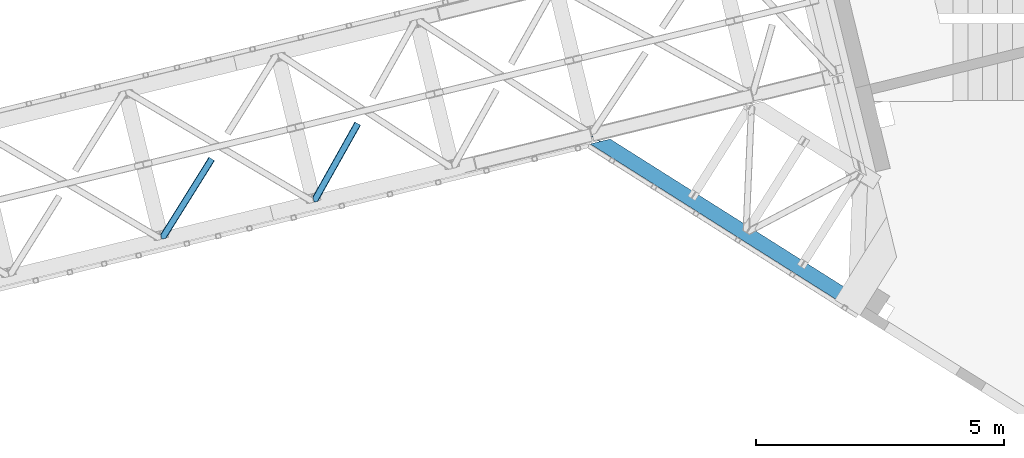
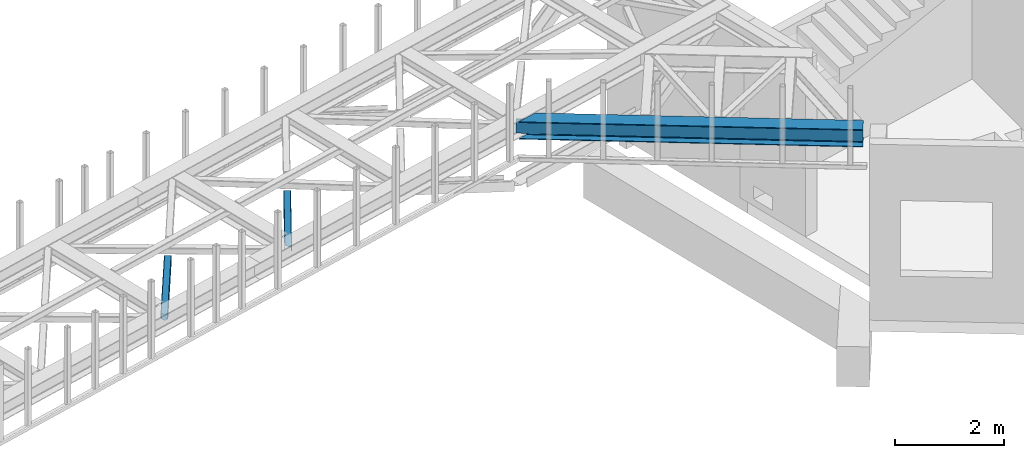
# One storey, part 48 of 67: 2 members, 1 beam.
"""IFC4 building model written with IfcOpenShell, lengths in millimetres."""

from ifc_helpers import new_model, entity, si_unit, converted_unit, derived_unit, direction, frame, origin, place, context, subcontext, project, spatial, triangles, polygons, material, type_object, element, save


model = new_model("IFC4")

# Units and contexts
model_context = context("Model", 3, precision=0.01, world=origin(), true_north=direction((6.12303176911189e-17, 1.0)))
plan_context = context("Plan", 3, precision=0.01, world=origin(), true_north=direction((6.12303176911189e-17, 1.0)))
body_context = subcontext(model_context, "Body", "Model", "MODEL_VIEW")
ifc_project = project(units=[si_unit("LENGTHUNIT", "METRE", prefix="MILLI"), si_unit("AREAUNIT", "SQUARE_METRE"), si_unit("VOLUMEUNIT", "CUBIC_METRE"), converted_unit("PLANEANGLEUNIT", "DEGREE", entity("IfcRatioMeasure", 0.0174532925199433), si_unit("PLANEANGLEUNIT", "RADIAN"), dimensions=[0, 0, 0, 0, 0, 0, 0]), si_unit("MASSUNIT", "GRAM", prefix="KILO"), derived_unit("MASSDENSITYUNIT", [(si_unit("MASSUNIT", "GRAM", prefix="KILO"), 1), (si_unit("LENGTHUNIT", "METRE"), -3)]), derived_unit("MOMENTOFINERTIAUNIT", [(si_unit("LENGTHUNIT", "METRE"), 4)]), si_unit("TIMEUNIT", "SECOND"), si_unit("FREQUENCYUNIT", "HERTZ"), si_unit("THERMODYNAMICTEMPERATUREUNIT", "DEGREE_CELSIUS"), derived_unit("THERMALTRANSMITTANCEUNIT", [(si_unit("MASSUNIT", "GRAM", prefix="KILO"), 1), (si_unit("THERMODYNAMICTEMPERATUREUNIT", "KELVIN"), -1), (si_unit("TIMEUNIT", "SECOND"), -3)]), derived_unit("VOLUMETRICFLOWRATEUNIT", [(si_unit("LENGTHUNIT", "METRE"), 3), (si_unit("TIMEUNIT", "SECOND"), -1)]), derived_unit("MASSFLOWRATEUNIT", [(si_unit("MASSUNIT", "GRAM", prefix="KILO"), 1), (si_unit("TIMEUNIT", "SECOND"), -1)]), derived_unit("ROTATIONALFREQUENCYUNIT", [(si_unit("TIMEUNIT", "SECOND"), -1)]), si_unit("ELECTRICCURRENTUNIT", "AMPERE"), si_unit("ELECTRICVOLTAGEUNIT", "VOLT"), si_unit("POWERUNIT", "WATT"), si_unit("FORCEUNIT", "NEWTON", prefix="KILO"), si_unit("ILLUMINANCEUNIT", "LUX"), si_unit("LUMINOUSFLUXUNIT", "LUMEN"), si_unit("LUMINOUSINTENSITYUNIT", "CANDELA"), derived_unit("USERDEFINED", [(si_unit("MASSUNIT", "GRAM", prefix="KILO"), -1), (si_unit("LENGTHUNIT", "METRE"), -2), (si_unit("TIMEUNIT", "SECOND"), 3), (si_unit("LUMINOUSFLUXUNIT", "LUMEN"), 1)]), derived_unit("LINEARVELOCITYUNIT", [(si_unit("LENGTHUNIT", "METRE"), 1), (si_unit("TIMEUNIT", "SECOND"), -1)]), si_unit("PRESSUREUNIT", "PASCAL"), derived_unit("USERDEFINED", [(si_unit("LENGTHUNIT", "METRE"), -2), (si_unit("MASSUNIT", "GRAM", prefix="KILO"), 1), (si_unit("TIMEUNIT", "SECOND"), -2)]), derived_unit("LINEARFORCEUNIT", [(si_unit("MASSUNIT", "GRAM", prefix="KILO"), 1), (si_unit("LENGTHUNIT", "METRE"), 1), (si_unit("TIMEUNIT", "SECOND"), -2), (si_unit("LENGTHUNIT", "METRE"), -1)]), derived_unit("PLANARFORCEUNIT", [(si_unit("MASSUNIT", "GRAM", prefix="KILO"), 1), (si_unit("LENGTHUNIT", "METRE"), 1), (si_unit("TIMEUNIT", "SECOND"), -2), (si_unit("LENGTHUNIT", "METRE"), -2)])], contexts=[model_context, plan_context])

# Site, building, storey
site_placement = place(None, origin())
site = spatial("IfcSite", under=ifc_project, at=site_placement, CompositionType="ELEMENT")
building_placement = place(site_placement, origin())
building = spatial("IfcBuilding", under=site, at=building_placement, CompositionType="ELEMENT")
storey_placement = place(building_placement, frame((0.0, 0.0, 19800.0)))
storey = spatial("IfcBuildingStorey", under=building, at=storey_placement, CompositionType="ELEMENT", Elevation=19800.0)

# Beam
ifc_material = material(Name="Metal painted (White)")
beam_type = type_object("IfcBeamType", PredefinedType="BEAM")
beam_placement = place(storey_placement, frame((-5441.52292405656, 12718.8983900712, 3716.0)))
element("IfcBeam", 1, at=beam_placement, inside=storey, type_object=beam_type, material=ifc_material, ObjectType="Steel Beam", PredefinedType="BEAM", context=body_context, shape_type="Tessellation", body=[
    polygons([(5348.49662777212, 2.16573425859679e-12, 376.000000000005), (4.33146851719357e-12, 3381.27208353849, 376.000000000005), (165.112842431303, 3421.52008574059, 376.000000000005), (1093.62086845177, 2834.52555508644, 376.000000000005), (2173.67127244742, 2151.72727848622, 376.000000000005), (3253.72167644305, 1468.92900188599, 376.000000000005), (4333.77208043868, 786.130725285767, 376.000000000005), (5413.82248443432, 103.332448685544, 376.000000000005), (5348.49662777212, 2.16573425859679e-12, 392.000000000002), (4.33146851719357e-12, 3381.27208353849, 392.000000000002), (5508.8054784769, 253.576561191515, 392.000000000002), (405.184889401983, 3480.04018710194, 392.000000000002), (210.481526452577, 3432.57918246201, 355.999999999997), (194.703362949402, 3428.73308817842, 356.000000000001), (192.564591019406, 3428.21173989272, 362.419035512026), (186.123501179538, 3426.64165609887, 369.556349186104), (176.483729007347, 3424.29185964512, 374.325349715248), (405.18488940198, 3480.04018710194, 376.000000000001), (240.072046970671, 3439.79218489983, 376.000000000005), (228.701160394625, 3437.02041099531, 374.325349715248), (219.061388222436, 3434.67061454155, 369.556349186099), (212.620298382568, 3433.1005307477, 362.419035512026), (5348.49662777213, 2.16573425859679e-12, 0.0), (5508.8054784769, 253.576561191515, 0.0), (5508.8054784769, 253.576561191517, 15.9999999999964), (5443.4796218147, 150.244112505971, 15.9999999999964), (5438.98080212478, 143.127878927001, 17.6746502847538), (5435.16688695074, 137.095027401615, 22.4436508138939), (5432.61851030462, 133.064004886613, 29.5809644879676), (5431.72363942969, 131.648498018593, 38.0), (5431.72363942968, 131.648498018593, 354.000000000002), (5432.61851030462, 133.064004886613, 362.419035512026), (5435.16688695074, 137.095027401613, 369.556349186099), (5438.98080212478, 143.127878927001, 374.325349715248), (5443.4796218147, 150.244112505971, 376.000000000005), (5508.8054784769, 253.576561191517, 376.000000000001), (5418.32130412425, 110.448682264514, 374.325349715248), (5422.13521929827, 116.481533789893, 369.556349186104), (5424.6835959444, 120.512556304904, 362.419035512026), (5425.57846681934, 121.928063172921, 354.000000000002), (5425.57846681934, 121.928063172921, 38.0), (5424.6835959444, 120.512556304902, 29.5809644879676), (5422.13521929827, 116.481533789891, 22.4436508138939), (5418.32130412425, 110.448682264514, 17.6746502847452), (5413.82248443432, 103.332448685544, 16.0000000000007), (5348.49662777213, 2.16573425859679e-12, 15.9999999999964), (4539.61123918262, 721.661679363439, 376.000000000005), (3635.74285655055, 1293.0792462209, 376.000000000005), (2731.87447391849, 1864.49681307837, 376.000000000005), (1828.00609128641, 2435.91437993584, 376.000000000005), (924.137708654353, 3007.3319467933, 376.000000000005), (4344.63319194877, 803.310832905123, 362.41903551203), (4345.5280628237, 804.726339773147, 354.000000000002), (3264.58278795313, 1486.10910950535, 362.419035512026), (3265.47765882807, 1487.52461637337, 354.000000000002), (2184.5323839575, 2168.90738610558, 362.41903551203), (2185.42725483244, 2170.3228929736, 354.000000000002), (1104.48197996186, 2851.70566270579, 362.419035512034), (1105.3768508368, 2853.12116957382, 354.000000000002), (4342.08481530264, 799.279810390127, 369.556349186104), (3262.034411307, 1482.07808699035, 369.556349186104), (2181.98400731137, 2164.87636359058, 369.556349186104), (1101.93360331573, 2847.6746401908, 369.556349186104), (4338.27090012861, 793.246958864737, 374.325349715252), (3258.22049613296, 1476.04523546496, 374.325349715252), (2178.17009213734, 2158.84351206519, 374.325349715248), (1098.1196881417, 2841.64178866541, 374.325349715252), (25.277767615974, 3535.84244536922, 356.000000000001), (25.3283289836519, 3535.91175797538, 353.999999604166), (4535.11241949271, 714.545445784473, 374.325349715248), (3631.24403686065, 1285.96301264194, 374.325349715248), (2727.37565422857, 1857.3805794994, 374.325349715248), (1823.5072715965, 2428.79814635686, 374.325349715244), (919.638888964427, 3000.21571321434, 374.325349715248), (4531.29850431868, 708.512594259083, 369.556349186099), (3627.43012168661, 1279.93016111655, 369.556349186104), (2723.56173905454, 1851.34772797402, 369.556349186104), (1819.69335642247, 2422.76529483148, 369.556349186104), (915.824973790396, 2994.18286168895, 369.556349186104), (4528.75012767254, 704.481571744081, 362.41903551203), (3624.88174504048, 1275.89913860154, 362.41903551203), (2721.01336240841, 1847.31670545901, 362.419035512034), (1817.14497977633, 2418.73427231648, 362.41903551203), (913.276597144272, 2990.15183917395, 362.419035512034), (4527.85525679761, 703.066064876057, 354.000000000002), (3623.98687416554, 1274.48363173353, 354.000000000002), (2720.11849153348, 1845.90119859099, 354.000000000002), (1816.2501089014, 2417.31876544846, 354.000000000002), (912.381726269338, 2988.73633230592, 354.000000000002), (40.8590053356167, 3539.70363258882, 353.999999900932), (40.9815723062875, 3539.73554863413, 356.000000000001), (25.3276901044207, 3535.9143676771, 35.9999997385271), (25.3273911802177, 3535.91558872633, 37.9999998013935), (40.8572852816821, 3539.71065868616, 38.0000002626733), (40.9802875962089, 3539.74079643359, 36.0000002701888), (1105.37685083679, 2853.12116957382, 38.0), (2185.42725483242, 2170.3228929736, 38.0), (3265.47765882807, 1487.52461637337, 38.0), (4345.5280628237, 804.726339773145, 38.0), (4527.85525679762, 703.066064876057, 38.0), (3623.98687416554, 1274.48363173353, 38.0), (2720.11849153347, 1845.90119859099, 38.0), (1816.2501089014, 2417.31876544846, 38.0), (912.381726269339, 2988.73633230592, 38.0), (4338.27090012861, 793.246958864737, 17.6746502847452), (4333.77208043868, 786.130725285767, 16.0000000000007), (3258.22049613296, 1476.04523546496, 17.6746502847495), (3253.72167644305, 1468.92900188599, 16.000000000005), (2178.17009213734, 2158.84351206518, 17.6746502847495), (2173.67127244742, 2151.72727848622, 16.0000000000007), (1098.1196881417, 2841.64178866541, 17.6746502847495), (1093.62086845177, 2834.52555508644, 16.0000000000007), (4342.08481530264, 799.279810390123, 22.4436508138939), (3262.034411307, 1482.07808699035, 22.4436508138939), (2181.98400731137, 2164.87636359058, 22.4436508138982), (1101.93360331573, 2847.67464019079, 22.4436508138895), (4344.63319194876, 803.310832905125, 29.5809644879676), (3264.58278795312, 1486.10910950534, 29.5809644879676), (2184.5323839575, 2168.90738610557, 29.5809644879676), (1104.48197996185, 2851.70566270579, 29.5809644879676), (192.564591019411, 3428.21173989272, 29.5809644879676), (186.123501179543, 3426.64165609887, 22.4436508138939), (176.483729007351, 3424.29185964512, 17.6746502847495), (165.112842431302, 3421.52008574059, 16.0000000000007), (194.703362949402, 3428.73308817842, 36.0000000000005), (4.33146851719357e-12, 3381.27208353849, 16.0000000000007), (3.24860138789518e-12, 3381.27208353849, 0.0), (240.072046970672, 3439.79218489983, 15.9999999999964), (405.18488940198, 3480.04018710194, 15.9999999999964), (405.184889401981, 3480.04018710194, 0.0), (210.481526452582, 3432.57918246201, 36.0000000000005), (212.620298382576, 3433.1005307477, 29.5809644879676), (219.061388222445, 3434.67061454156, 22.4436508138939), (228.701160394625, 3437.02041099531, 17.6746502847495), (924.137708654352, 3007.3319467933, 16.0000000000007), (1828.00609128641, 2435.91437993584, 16.0000000000007), (2731.87447391849, 1864.49681307837, 16.0000000000007), (3635.74285655055, 1293.0792462209, 16.0000000000007), (4539.61123918262, 721.661679363439, 16.0000000000007), (4528.75012767254, 704.481571744079, 29.5809644879676), (3624.88174504048, 1275.89913860154, 29.5809644879676), (2721.01336240841, 1847.31670545901, 29.5809644879676), (1817.14497977633, 2418.73427231648, 29.5809644879719), (913.276597144274, 2990.15183917395, 29.5809644879676), (4531.29850431868, 708.512594259083, 22.4436508138939), (3627.43012168661, 1279.93016111655, 22.4436508138982), (2723.56173905453, 1851.34772797402, 22.4436508138939), (1819.69335642247, 2422.76529483147, 22.4436508138982), (915.824973790397, 2994.18286168895, 22.4436508138982), (4535.11241949271, 714.545445784471, 17.6746502847538), (3631.24403686065, 1285.96301264194, 17.6746502847495), (2727.37565422857, 1857.3805794994, 17.6746502847538), (1823.5072715965, 2428.79814635687, 17.6746502847538), (919.638888964427, 3000.21571321434, 17.6746502847495)], [[[1, 2, 3, 4, 5, 6, 7, 8]], [[9, 10, 2, 1]], [[11, 12, 10, 9]], [[13, 14, 15, 16, 17, 3, 2, 10, 12, 18, 19, 20, 21, 22]], [[23, 24, 25, 26, 27, 28, 29, 30, 31, 32, 33, 34, 35, 36, 11, 9, 1, 8, 37, 38, 39, 40, 41, 42, 43, 44, 45, 46]], [[36, 18, 12, 11]], [[35, 47, 48, 49, 50, 51, 19, 18, 36]], [[52, 53, 40, 39]], [[54, 55, 53, 52]], [[56, 57, 55, 54]], [[58, 59, 57, 56]], [[60, 52, 39, 38]], [[61, 54, 52, 60]], [[62, 56, 54, 61]], [[63, 58, 56, 62]], [[64, 60, 38, 37]], [[65, 61, 60, 64]], [[66, 62, 61, 65]], [[67, 63, 62, 66]], [[7, 64, 37, 8]], [[6, 65, 64, 7]], [[5, 66, 65, 6]], [[4, 67, 66, 5]], [[3, 17, 67, 4]], [[17, 16, 63, 67]], [[16, 15, 58, 63]], [[59, 14, 68, 69]], [[58, 14, 59]], [[14, 58, 15]], [[70, 47, 35, 34]], [[71, 48, 47, 70]], [[72, 49, 48, 71]], [[73, 50, 49, 72]], [[74, 51, 50, 73]], [[75, 70, 34, 33]], [[76, 71, 70, 75]], [[77, 72, 71, 76]], [[78, 73, 72, 77]], [[79, 74, 73, 78]], [[80, 75, 33, 32]], [[81, 76, 75, 80]], [[82, 77, 76, 81]], [[83, 78, 77, 82]], [[84, 79, 78, 83]], [[85, 80, 32, 31]], [[86, 81, 80, 85]], [[87, 82, 81, 86]], [[88, 83, 82, 87]], [[89, 84, 83, 88]], [[22, 21, 79, 84]], [[21, 20, 74, 79]], [[20, 19, 51, 74]], [[13, 90, 91]], [[84, 13, 22]], [[89, 13, 84]], [[13, 89, 90]], [[91, 68, 14, 13]], [[92, 93, 69, 68, 91, 90, 94, 95]], [[69, 93, 96, 97, 98, 99, 41, 40, 53, 55, 57, 59]], [[30, 100, 101, 102, 103, 104, 94, 90, 89, 88, 87, 86, 85, 31]], [[105, 106, 45, 44]], [[107, 108, 106, 105]], [[109, 110, 108, 107]], [[111, 112, 110, 109]], [[113, 105, 44, 43]], [[114, 107, 105, 113]], [[115, 109, 107, 114]], [[116, 111, 109, 115]], [[117, 113, 43, 42]], [[118, 114, 113, 117]], [[119, 115, 114, 118]], [[120, 116, 115, 119]], [[99, 117, 42, 41]], [[98, 118, 117, 99]], [[97, 119, 118, 98]], [[96, 120, 119, 97]], [[121, 122, 116, 120]], [[122, 123, 111, 116]], [[123, 124, 112, 111]], [[125, 93, 92]], [[120, 125, 121]], [[96, 125, 120]], [[125, 96, 93]], [[46, 126, 127, 23]], [[45, 106, 108, 110, 112, 124, 126, 46]], [[128, 129, 130, 127, 126, 124, 123, 122, 121, 125, 131, 132, 133, 134]], [[23, 127, 130, 24]], [[24, 130, 129, 25]], [[25, 129, 128, 135, 136, 137, 138, 139, 26]], [[140, 100, 30, 29]], [[141, 101, 100, 140]], [[142, 102, 101, 141]], [[143, 103, 102, 142]], [[144, 104, 103, 143]], [[145, 140, 29, 28]], [[146, 141, 140, 145]], [[147, 142, 141, 146]], [[148, 143, 142, 147]], [[149, 144, 143, 148]], [[150, 145, 28, 27]], [[151, 146, 145, 150]], [[152, 147, 146, 151]], [[153, 148, 147, 152]], [[154, 149, 148, 153]], [[139, 150, 27, 26]], [[138, 151, 150, 139]], [[137, 152, 151, 138]], [[136, 153, 152, 137]], [[135, 154, 153, 136]], [[128, 134, 154, 135]], [[134, 133, 149, 154]], [[133, 132, 144, 149]], [[104, 131, 95, 94]], [[104, 132, 131]], [[132, 104, 144]], [[131, 125, 92, 95]]], closed=True),
])

# Members
member_type_1 = type_object("IfcMemberType", PredefinedType="BRACE")
member_1_placement = place(storey_placement, frame((-11031.4278167725, 14926.1819458008, 3822.99993896484)))
element("IfcMember", 2, at=member_1_placement, inside=storey, type_object=member_type_1, ObjectType="Steel Horizontal Brace", PredefinedType="BRACE", context=body_context, shape_type="Tessellation", body=[
    triangles([(967.681631469726, 1549.66471252442, 122.499499511719), (966.517749023436, 1550.31583557129, 129.196765136719), (108.48872680664, 19.7604217529297, 122.499499511719), (106.717904663084, 19.3290527343761, 129.196765136719), (963.210974121093, 1552.17386169434, 134.87548828125), (101.675189208983, 18.1000579833999, 134.87548828125), (958.258950805663, 1554.95276184082, 138.668280029298), (94.1337890625, 16.2617980957039, 138.668280029298), (952.418609619141, 1558.23279418945, 140.00075683594), (85.2320068359368, 14.0921630859375, 140.00075683594), (967.681631469726, 1549.66471252442, 17.5012573242202), (108.48872680664, 19.7604217529297, 17.5012573242202), (6.07521057128906, 87.5702362060547, 140.00075683594), (27.4215820312493, 0.0, 140.00075683594), (860.870709228515, 1609.64826049805, 140.00075683594), (855.030368041991, 1612.92713012695, 138.668280029298), (3.75093383788953, 97.1068634033218, 138.668280029298), (850.082995605468, 1615.70719299317, 134.87548828125), (1.7801239013661, 105.192416381837, 134.87548828125), (846.772732543945, 1617.56405639648, 129.196765136719), (0.46276245117042, 110.594412231447, 129.196765136719), (845.612338256835, 1618.21750488281, 122.499499511719), (0.0, 112.491970825196, 122.499499511719), (845.612338256835, 1618.21750488281, 17.5012573242202), (0.0, 112.491970825196, 17.5012573242202), (966.517749023436, 1550.31583557129, 10.8039916992202), (963.210974121093, 1552.17386169434, 5.12526855468968), (157.746185302734, 111.400177001953, 9.52034912109593), (158.140347290038, 112.965197753907, 8.76225585937573), (158.27173461914, 113.467492675782, 8.52041015625218), (157.353186035156, 117.235867309571, 5.12526855468968), (106.36094970703, 19.2418487548839, 10.8691040039084), (105.931906127929, 19.1372039794933, 9.52034912109593), (952.418609619141, 1558.23279418945, 0.0), (958.258950805663, 1554.95276184082, 1.33247680664135), (153.058099365233, 134.858047485352, 0.0), (155.382376098632, 125.321420288086, 1.33247680664135), (124.438916015624, 252.261346435547, 0.0), (94.4581878662102, 244.952490234376, 0.0), (860.870709228515, 1609.64826049805, 0.0), (153.051123046875, 130.664117431641, 9.52034912109593), (153.142977905272, 131.5815032959, 9.31571044922021), (153.232507324217, 132.509353637695, 9.1087463378899), (153.325524902342, 133.426739501954, 8.90410766601781), (152.944152832031, 135.321972656251, 8.42274169921802), (87.952770996093, 14.7549133300781, 9.52034912109593), (150.628015136717, 144.8272064209, 6.99957275390625), (124.438916015624, 252.261346435547, 6.99957275390625), (952.15816040039, 1558.38162231445, 8.3320495605476), (946.317819213866, 1561.66049194336, 6.99957275390625), (957.105532836913, 1555.60039672852, 12.1248413085959), (92.375756835936, 15.832754516603, 12.1248413085959), (961.576190185546, 1553.09124755859, 24.5008300781265), (960.415795898436, 1553.7435333252, 17.8035644531265), (99.1858062744141, 17.4931182861328, 24.5008300781265), (97.4138214111317, 17.0617492675792, 17.8035644531265), (103.762271118163, 247.220956420899, 6.99957275390625), (866.972662353515, 1606.21940002442, 6.99957275390625), (85.5610565185543, 242.784017944337, 1.33247680664135), (91.7385864257813, 244.289739990236, 9.52034912109593), (78.0161682128892, 240.944595336914, 5.12526855468968), (95.0593139648427, 245.098992919922, 8.82504272460938), (73.7641021728505, 239.908612060548, 9.52034912109593), (846.772732543945, 1617.56405639648, 10.8039916992202), (4.59390563964735, 117.490502929688, 10.8714294433594), (850.082995605468, 1615.70719299317, 5.12526855468968), (5.69267578124891, 118.696243286133, 9.52034912109593), (855.030368041991, 1612.92713012695, 1.33247680664135), (0.0104644775383349, 112.452438354492, 16.5199218750022), (10.3889007568359, 99.4323028564468, 9.52034912109593), (7.36001586914063, 100.839193725587, 12.1248413085959), (3.09864807128906, 99.7811187744155, 16.5199218750022), (852.878173828125, 1614.13752136231, 17.8035644531265), (851.714291381835, 1614.78864440918, 24.5008300781265), (2.43008422851563, 102.522811889648, 24.5008300781265), (2.98586425781104, 100.243881225586, 17.8686767578147), (856.183786010741, 1612.27949523926, 12.1248413085959), (861.136972045897, 1609.49943237305, 8.3320495605476), (961.576190185546, 1553.09124755859, 115.499926757813), (99.1858062744141, 17.4931182861328, 115.499926757813), (97.4138214111317, 17.0617492675792, 122.197192382813), (84.8297058105454, 13.9933319091797, 131.668707275392), (75.9325744628895, 11.8248596191406, 133.001184082033), (27.4215820312493, 0.0, 133.001184082033), (92.375756835936, 15.832754516603, 127.873590087893), (946.317819213866, 1561.66049194336, 133.001184082033), (952.15816040039, 1558.38162231445, 131.668707275392), (957.105532836913, 1555.60039672852, 127.873590087893), (960.415795898436, 1553.7435333252, 122.197192382813), (856.183786010741, 1612.27949523926, 127.873590087893), (866.972662353515, 1606.21940002442, 133.001184082033), (861.136972045897, 1609.49943237305, 131.668707275392), (851.714291381835, 1614.78864440918, 115.499926757813), (852.878173828125, 1614.13752136231, 122.197192382813), (6.18101806640516, 87.1388671875011, 131.668707275392), (8.50529479980469, 77.6010772705085, 133.001184082033), (4.21020812988172, 95.2232574462905, 127.873590087893), (2.43008422851563, 102.522811889648, 115.499926757813), (2.89284667968604, 100.626416015626, 122.197192382813)], [[1, 2, 3], [4, 3, 2], [2, 5, 4], [6, 4, 5], [5, 7, 6], [8, 6, 7], [7, 9, 8], [10, 8, 9], [11, 1, 3], [3, 12, 11], [13, 10, 9], [10, 13, 14], [9, 15, 13], [15, 16, 17], [17, 13, 15], [16, 18, 19], [19, 17, 16], [18, 20, 21], [21, 19, 18], [20, 22, 23], [23, 21, 20], [22, 24, 25], [25, 23, 22], [26, 11, 12], [27, 28, 29], [30, 31, 27], [26, 32, 28], [28, 27, 26], [32, 33, 28], [34, 35, 36], [37, 36, 35], [35, 27, 37], [31, 37, 27], [12, 32, 26], [38, 39, 40], [36, 38, 34], [40, 34, 38], [41, 42, 28], [42, 43, 29], [43, 44, 29], [44, 45, 30], [33, 46, 28], [41, 28, 46], [45, 47, 36], [38, 47, 48], [47, 38, 36], [45, 31, 30], [45, 36, 37], [37, 31, 45], [49, 50, 47], [51, 49, 45], [45, 44, 51], [51, 43, 42], [43, 51, 44], [42, 41, 51], [51, 41, 52], [46, 52, 41], [47, 45, 49], [53, 54, 55], [56, 55, 54], [54, 51, 56], [52, 56, 51], [48, 47, 50], [57, 48, 58], [50, 58, 48], [59, 60, 61], [57, 38, 48], [57, 62, 39], [57, 39, 38], [39, 60, 59], [61, 60, 63], [62, 60, 39], [24, 64, 65], [65, 25, 24], [65, 64, 63], [64, 66, 61], [61, 63, 64], [63, 67, 65], [66, 68, 59], [59, 61, 66], [68, 40, 39], [39, 59, 68], [65, 69, 25], [65, 70, 71], [65, 67, 70], [71, 69, 65], [72, 69, 71], [70, 67, 60], [63, 60, 67], [73, 74, 75], [73, 72, 71], [73, 76, 72], [77, 71, 60], [60, 78, 77], [60, 62, 78], [71, 70, 60], [78, 62, 57], [57, 58, 78], [71, 77, 73], [75, 76, 73], [79, 53, 55], [55, 80, 79], [81, 3, 4], [82, 8, 10], [14, 83, 10], [83, 14, 84], [83, 82, 10], [85, 8, 82], [85, 81, 6], [6, 8, 85], [4, 6, 81], [55, 12, 3], [52, 33, 56], [81, 80, 3], [52, 46, 33], [55, 56, 12], [80, 55, 3], [32, 12, 56], [56, 33, 32], [86, 87, 82], [82, 83, 86], [87, 88, 85], [85, 82, 87], [88, 89, 81], [81, 85, 88], [89, 79, 80], [80, 81, 89], [26, 51, 54], [53, 1, 11], [26, 54, 11], [26, 27, 51], [54, 53, 11], [51, 27, 35], [50, 34, 40], [34, 49, 35], [49, 34, 50], [49, 51, 35], [2, 88, 5], [79, 1, 53], [1, 89, 2], [89, 1, 79], [2, 89, 88], [9, 86, 15], [7, 5, 88], [88, 87, 7], [87, 86, 9], [9, 7, 87], [77, 68, 66], [40, 58, 50], [40, 78, 58], [78, 40, 68], [77, 78, 68], [74, 24, 22], [64, 73, 77], [66, 64, 77], [73, 64, 24], [74, 73, 24], [16, 90, 18], [15, 86, 91], [91, 92, 15], [92, 90, 16], [16, 15, 92], [20, 18, 90], [22, 93, 74], [94, 22, 20], [22, 94, 93], [94, 20, 90], [95, 96, 13], [96, 14, 13], [96, 84, 14], [17, 95, 13], [97, 17, 19], [97, 95, 17], [72, 76, 69], [23, 98, 99], [99, 19, 21], [19, 99, 97], [21, 23, 99], [23, 75, 98], [25, 69, 76], [25, 75, 23], [75, 25, 76], [83, 96, 86], [83, 84, 96], [91, 86, 96], [74, 93, 75], [98, 75, 93], [93, 94, 98], [99, 98, 94], [94, 90, 99], [97, 99, 90], [90, 92, 97], [95, 97, 92], [92, 91, 95], [96, 95, 91]]),
])
member_type_2 = type_object("IfcMemberType", PredefinedType="BRACE")
member_2_placement = place(storey_placement, frame((-14098.6743164063, 14177.8101837158, 3822.99993896484)))
element("IfcMember", 3, at=member_2_placement, inside=storey, type_object=member_type_2, ObjectType="Steel Horizontal Brace", PredefinedType="BRACE", context=body_context, shape_type="Tessellation", body=[
    triangles([(986.151434326172, 1647.42967529297, 0.0), (1075.22041625976, 1591.82725524902, 0.0), (119.789199829102, 259.603921508789, 0.0), (154.549868774413, 117.004486083984, 0.0), (115.90339050293, 275.545971679687, 4.52065429687718), (117.571893310547, 268.699877929686, 1.33247680664135), (158.435678100586, 101.063598632813, 4.52065429687718), (156.766012573242, 107.909692382813, 1.33247680664135), (114.825549316405, 275.743634033202, 5.52059326172093), (115.131344604491, 275.92385559082, 5.35316162109302), (158.132208251953, 99.1230194091786, 5.27642211914281), (115.440628051758, 276.108728027344, 5.18107910156323), (158.235690307616, 99.7787933349609, 5.02062377929906), (158.189181518554, 99.4822998046875, 5.13457031250073), (115.540621948241, 276.168026733398, 5.12526855468968), (115.687124633789, 275.922692871094, 4.88574829101708), (158.339172363281, 100.434567260741, 4.76482543945531), (158.032214355468, 98.4939880371094, 5.52059326172093), (1085.71744995117, 1585.27416687012, 5.12526855468968), (1080.90146484375, 1588.28096008301, 1.33247680664135), (1088.9358581543, 1583.26614990234, 10.8039916992202), (114.209307861327, 21.8533172607422, 10.8039916992202), (109.470062255859, 20.697573852538, 5.52059326172093), (1090.06485900879, 1582.56037902832, 17.5012573242202), (116.062683105469, 22.3044525146488, 17.5012573242202), (6.75075073242078, 102.619317626953, 5.52059326172093), (31.3620391845707, 1.65803833007703, 5.52059326172093), (1090.06485900879, 1582.56037902832, 122.499499511719), (116.062683105469, 22.3044525146488, 122.499499511719), (1088.9358581543, 1583.26614990234, 129.196765136719), (114.209307861327, 21.8533172607422, 129.196765136719), (1085.71744995117, 1585.27416687012, 134.87548828125), (108.936373901366, 20.5673492431633, 134.87548828125), (1080.90146484375, 1588.28096008301, 138.668280029298), (101.042669677734, 18.6430480957024, 138.668280029298), (1075.22041625976, 1591.82725524902, 140.00075683594), (91.7292846679684, 16.3734191894528, 140.00075683594), (980.470385742186, 1650.97597045899, 1.33247680664135), (975.654400634765, 1653.98276367187, 5.12526855468968), (1.68826904296839, 100.41131286621, 10.9621215820334), (972.43599243164, 1655.99194335938, 10.8039916992202), (971.306991577148, 1656.69655151367, 17.5012573242202), (0.239520263670784, 99.7787933349609, 12.5201660156272), (0.0, 100.761291503906, 17.5012573242202), (5.79266967773401, 76.9941375732415, 140.00075683594), (986.151434326172, 1647.42967529297, 140.00075683594), (24.5612915039055, 0.0, 140.00075683594), (971.306991577148, 1656.69655151367, 122.499499511719), (0.0, 100.761291503906, 122.499499511719), (980.470385742186, 1650.97597045899, 138.668280029298), (3.57652587890516, 86.088931274413, 138.668280029298), (975.654400634765, 1653.98276367187, 134.87548828125), (1.69640808105396, 93.8000885009769, 134.87548828125), (972.43599243164, 1655.99194335938, 129.196765136719), (0.44067077636646, 98.9520996093743, 129.196765136719), (29.9249176025387, 1.30805969238281, 6.99957275390625), (12.1969299316406, 74.0338531494144, 6.99957275390625), (8.9959625244137, 81.5496734619137, 8.3320495605476), (3.8869720458988, 84.8122650146488, 12.5201660156272), (1069.28589477539, 1595.53516845703, 6.99957275390625), (81.996157836913, 14.0014709472653, 6.99957275390625), (992.090606689453, 1643.72292480469, 6.99957275390625), (981.593572998047, 1650.27601318359, 12.1248413085959), (978.376327514648, 1652.28519287109, 17.8035644531265), (2.75797119140589, 89.4457031250004, 17.8035644531265), (986.410720825195, 1647.2692199707, 8.3320495605476), (977.24616394043, 1652.99096374512, 24.5008300781265), (2.31730041503943, 91.2548950195305, 24.5008300781265), (977.24616394043, 1652.99096374512, 115.499926757813), (2.31730041503943, 91.2548950195305, 115.499926757813), (4.01370849609339, 84.2936920166012, 127.873590087893), (2.75797119140589, 89.4457031250004, 122.197192382813), (5.89382629394458, 76.5825347900391, 131.668707275392), (8.10997009277344, 67.4877410888676, 133.001184082033), (24.5612915039055, 0.0, 133.001184082033), (978.376327514648, 1652.28519287109, 122.197192382813), (981.593572998047, 1650.27601318359, 127.873590087893), (986.410720825195, 1647.2692199707, 131.668707275392), (992.090606689453, 1643.72292480469, 133.001184082033), (1069.28589477539, 1595.53516845703, 133.001184082033), (81.996157836913, 14.0014709472653, 133.001184082033), (1079.78176574707, 1588.98208007813, 12.1248413085959), (1083.00017395019, 1586.97290039063, 17.8035644531265), (1084.13033752441, 1586.2671295166, 24.5008300781265), (1074.96578063965, 1591.98887329101, 8.3320495605476), (1079.78176574707, 1588.98208007813, 127.873590087893), (1084.13033752441, 1586.2671295166, 115.499926757813), (1083.00017395019, 1586.97290039063, 122.197192382813), (1074.96578063965, 1591.98887329101, 131.668707275392), (91.3095428466786, 16.2710998535149, 131.668707275392), (99.2032470703125, 18.1954010009758, 127.873590087893), (104.476181030273, 19.4802062988274, 122.197192382813), (106.329556274413, 19.9325042724613, 115.499926757813), (91.3095428466786, 16.2710998535149, 8.3320495605476), (104.476181030273, 19.4802062988274, 17.8035644531265), (99.2032470703125, 18.1954010009758, 12.1248413085959), (106.329556274413, 19.9325042724613, 24.5008300781265)], [[1, 2, 3], [4, 3, 2], [5, 3, 4], [3, 5, 6], [4, 7, 5], [7, 4, 8], [9, 10, 11], [10, 12, 13], [13, 14, 10], [12, 15, 16], [16, 17, 12], [16, 5, 7], [7, 17, 16], [17, 13, 12], [14, 11, 10], [11, 18, 9], [19, 14, 13], [13, 20, 19], [13, 17, 20], [17, 7, 20], [7, 8, 20], [21, 22, 18], [18, 19, 21], [14, 19, 11], [18, 11, 19], [22, 23, 18], [21, 24, 25], [25, 22, 21], [2, 20, 4], [8, 4, 20], [23, 26, 18], [23, 27, 26], [9, 18, 26], [24, 28, 29], [29, 25, 24], [28, 30, 29], [31, 29, 30], [30, 32, 31], [33, 31, 32], [32, 34, 33], [35, 33, 34], [34, 36, 35], [37, 35, 36], [38, 6, 5], [5, 39, 38], [39, 5, 16], [16, 15, 39], [40, 41, 9], [41, 39, 15], [15, 12, 41], [12, 9, 41], [42, 41, 40], [40, 43, 42], [43, 44, 42], [9, 26, 40], [38, 1, 6], [3, 6, 1], [36, 45, 37], [36, 46, 45], [45, 47, 37], [48, 42, 44], [44, 49, 48], [46, 50, 51], [51, 45, 46], [50, 52, 53], [53, 51, 50], [52, 54, 55], [55, 53, 52], [54, 48, 49], [49, 55, 54], [27, 56, 57], [26, 57, 58], [57, 26, 27], [59, 40, 26], [26, 58, 59], [43, 40, 59], [60, 57, 61], [60, 62, 57], [57, 56, 61], [63, 64, 65], [65, 59, 63], [66, 63, 59], [62, 66, 58], [58, 57, 62], [59, 58, 66], [64, 67, 68], [68, 65, 64], [67, 69, 70], [70, 68, 67], [71, 53, 72], [73, 74, 45], [74, 47, 45], [74, 75, 47], [51, 73, 45], [71, 51, 53], [71, 73, 51], [49, 68, 70], [55, 72, 53], [70, 72, 49], [72, 55, 49], [44, 68, 49], [43, 59, 65], [65, 68, 44], [44, 43, 65], [69, 76, 70], [72, 70, 76], [76, 77, 72], [71, 72, 77], [77, 78, 71], [73, 71, 78], [78, 79, 73], [74, 73, 79], [80, 74, 79], [74, 80, 81], [75, 74, 81], [21, 82, 83], [84, 28, 24], [21, 83, 24], [21, 19, 82], [83, 84, 24], [82, 19, 20], [60, 2, 1], [2, 85, 20], [85, 2, 60], [85, 82, 20], [30, 86, 32], [87, 28, 84], [28, 88, 30], [88, 28, 87], [30, 88, 86], [36, 80, 46], [34, 32, 86], [86, 89, 34], [89, 80, 36], [36, 34, 89], [63, 38, 39], [1, 62, 60], [1, 66, 62], [66, 1, 38], [63, 66, 38], [67, 42, 48], [41, 64, 63], [39, 41, 63], [64, 41, 42], [67, 64, 42], [50, 77, 52], [46, 80, 79], [79, 78, 46], [78, 77, 50], [50, 46, 78], [54, 52, 77], [48, 69, 67], [76, 48, 54], [48, 76, 69], [76, 54, 77], [35, 37, 90], [47, 81, 37], [81, 47, 75], [81, 90, 37], [91, 35, 90], [91, 33, 35], [33, 92, 31], [92, 33, 91], [29, 92, 93], [92, 29, 31], [61, 23, 94], [95, 96, 23], [96, 94, 23], [61, 27, 23], [27, 61, 56], [97, 95, 25], [22, 25, 95], [29, 97, 25], [97, 29, 93], [95, 23, 22], [80, 89, 90], [90, 81, 80], [89, 86, 91], [91, 90, 89], [86, 88, 92], [92, 91, 86], [88, 87, 93], [93, 92, 88], [87, 84, 97], [97, 93, 87], [84, 83, 97], [95, 97, 83], [83, 82, 95], [96, 95, 82], [82, 85, 96], [94, 96, 85], [85, 60, 94], [61, 94, 60]]),
])

save(model, "model.ifc")
